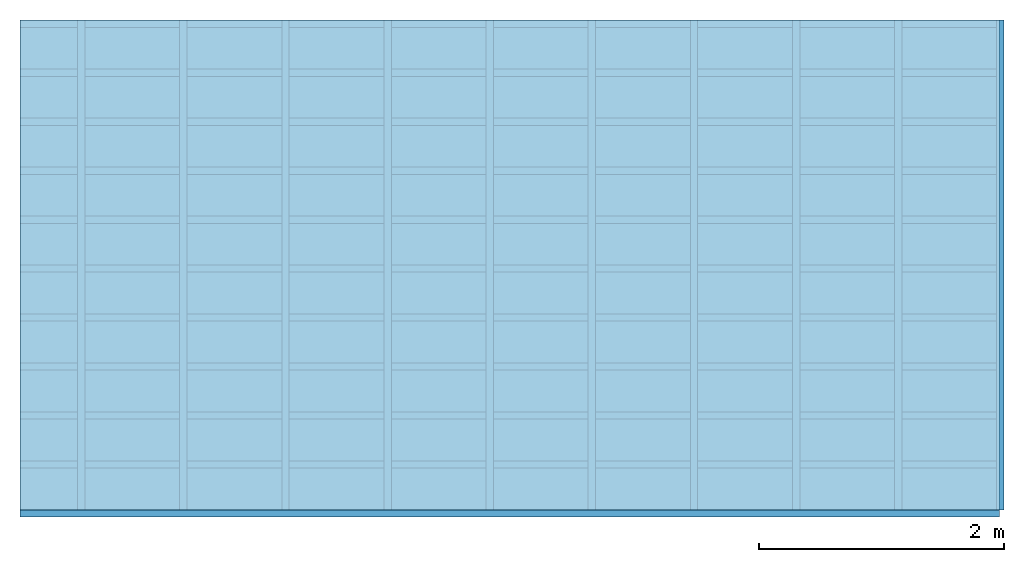
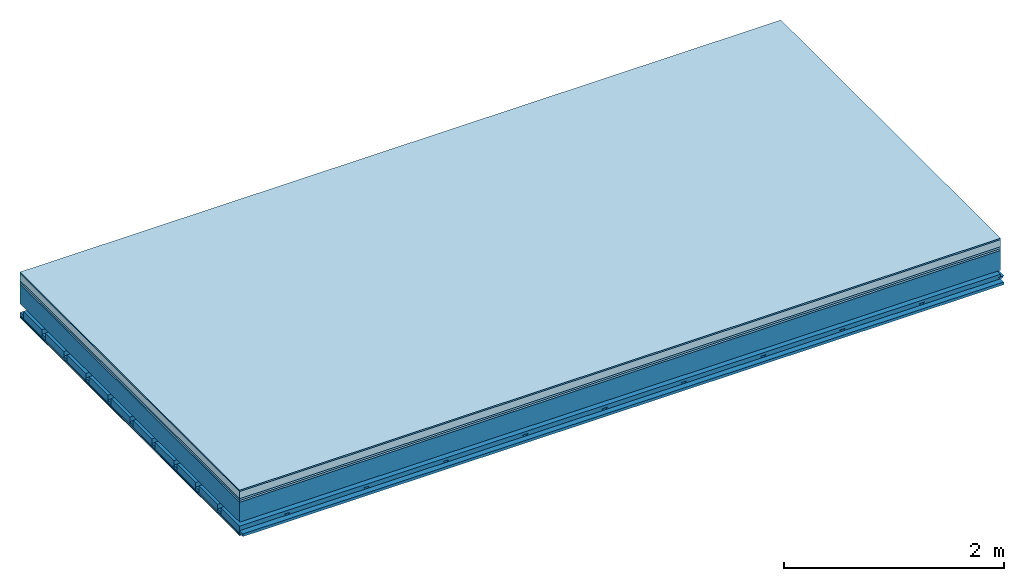
# One storey: 7 plates, 4 members, 1 element without a shape of its own.
"""IFC4 building model written with IfcOpenShell, lengths in metres."""

import ifcopenshell
import ifcopenshell.guid

model = None  # the IFC model being written
_history = None  # IfcOwnerHistory: only IFC2X3 demands one
_inside = {}  # id of a spatial element -> (the spatial element, [elements in it])
_under = {}  # id of a project, library or spatial element -> (it, [spatial elements below it])
_declared = {}  # id of a project -> (the project, [libraries it declares])
_typed = {}  # id of a type object -> (the type object, [elements of that type])
_made_of = {}  # id of a material, layer set ... -> (it, [elements and type objects made of it])


def new_model(schema):
    """Start an empty IFC model of exactly this schema.

    Asked for "IFC4X3", IfcOpenShell would pick the latest addendum, in which some entities
    have other attributes; the version numbers below select the first issue.
    IFC2X3 requires an IfcOwnerHistory on every rooted entity: one is made here for all.
    """
    global model, _history
    if schema == "IFC4X3":
        model = ifcopenshell.file(schema_version=(4, 3, 0, 0))
    else:
        model = ifcopenshell.file(schema=schema)
    _inside.clear()
    _under.clear()
    _declared.clear()
    _typed.clear()
    _made_of.clear()
    _history = None
    if model.schema == "IFC2X3":
        org = make("IfcOrganization", Name="unknown")
        user = make(
            "IfcPersonAndOrganization",
            ThePerson=make("IfcPerson", FamilyName="unknown"),
            TheOrganization=org,
        )
        app = make(
            "IfcApplication",
            ApplicationDeveloper=org,
            Version="unknown",
            ApplicationFullName="unknown",
            ApplicationIdentifier="unknown",
        )
        _history = make(
            "IfcOwnerHistory",
            OwningUser=user,
            OwningApplication=app,
            ChangeAction="ADDED",
            CreationDate=0,
        )
    return model


def make(cls, **values):
    """One entity of the class cls with the attributes given. An attribute that is None is left unset."""
    return model.create_entity(
        cls, **{name: value for name, value in values.items() if value is not None}
    )


def rooted(cls, **values):
    """An entity with a GlobalId (a new one), such as an element, a storey or a relation."""
    return make(cls, GlobalId=ifcopenshell.guid.new(), OwnerHistory=_history, **values)


def si_unit(unit_type, name, prefix=None):
    """IfcSIUnit, for example si_unit("LENGTHUNIT", "METRE", prefix="MILLI")."""
    return make("IfcSIUnit", UnitType=unit_type, Prefix=prefix, Name=name)


def derived_unit(unit_type, elements):
    """IfcDerivedUnit: a product of units, each with its exponent."""
    return make(
        "IfcDerivedUnit",
        Elements=[
            make("IfcDerivedUnitElement", Unit=unit, Exponent=power)
            for unit, power in elements
        ],
        UnitType=unit_type,
    )


def assignment(units):
    """IfcUnitAssignment: the units of a project."""
    return None if units is None else make("IfcUnitAssignment", Units=units)


def point(xyz):
    """IfcCartesianPoint."""
    return None if xyz is None else make("IfcCartesianPoint", Coordinates=xyz)


def direction(xyz):
    """IfcDirection."""
    return None if xyz is None else make("IfcDirection", DirectionRatios=xyz)


def frame(location, z_axis=None, x_axis=None):
    """IfcAxis2Placement3D, a coordinate frame: its origin and axes. An axis left out is left unset."""
    return make(
        "IfcAxis2Placement3D",
        Location=point(location),
        Axis=direction(z_axis),
        RefDirection=direction(x_axis),
    )


def frame_2d(location, x_axis=None):
    """IfcAxis2Placement2D, a coordinate frame in the plane: its origin and x axis."""
    return make(
        "IfcAxis2Placement2D", Location=point(location), RefDirection=direction(x_axis)
    )


def origin():
    """The frame at (0, 0, 0) with its axes left unset."""
    return frame((0.0, 0.0, 0.0))


def origin_with_axes():
    """The frame at (0, 0, 0) with the z axis (0, 0, 1) and the x axis (1, 0, 0) written out."""
    return frame((0.0, 0.0, 0.0), z_axis=(0.0, 0.0, 1.0), x_axis=(1.0, 0.0, 0.0))


def place(relative_to, where):
    """IfcLocalPlacement: puts the frame where relative to a parent placement (None: the world)."""
    return make(
        "IfcLocalPlacement", PlacementRelTo=relative_to, RelativePlacement=where
    )


def context(
    kind, dimensions, precision=None, world=None, true_north=None, identifier=None
):
    """IfcGeometricRepresentationContext, for example the 3D "Model" context."""
    return make(
        "IfcGeometricRepresentationContext",
        ContextIdentifier=identifier,
        ContextType=kind,
        CoordinateSpaceDimension=dimensions,
        Precision=precision,
        WorldCoordinateSystem=world,
        TrueNorth=true_north,
    )


def project(units=None, contexts=None):
    """IfcProject with its units and contexts."""
    return rooted(
        "IfcProject",
        Name="project",
        RepresentationContexts=contexts,
        UnitsInContext=assignment(units),
    )


def spatial(cls, under=None, at=None, **own):
    """A site, building, storey or space (cls), placed at a placement, below another one or the project."""
    s = rooted(cls, ObjectPlacement=at, **own)
    if under is not None:
        _under.setdefault(under.id(), (under, []))[1].append(s)
    return s


def polyline(points):
    """IfcPolyline through the points."""
    return make("IfcPolyline", Points=[point(p) for p in points])


def profile(cls, at=None, kind="AREA", **sizes):
    """A parametric profile (cls). Its sizes go by their IFC names, for example OverallWidth=200.0."""
    return make(cls, ProfileType=kind, Position=at, **sizes)


def rectangle(**sizes):
    """IfcRectangleProfileDef."""
    return profile("IfcRectangleProfileDef", **sizes)


def outline(outer, holes=None, kind="AREA"):
    """IfcArbitraryClosedProfileDef: a profile drawn as a closed curve; with holes, ...WithVoids."""
    if holes is None:
        return make("IfcArbitraryClosedProfileDef", ProfileType=kind, OuterCurve=outer)
    return make(
        "IfcArbitraryProfileDefWithVoids",
        ProfileType=kind,
        OuterCurve=outer,
        InnerCurves=holes,
    )


def extrude(swept, where, along, depth):
    """IfcExtrudedAreaSolid: the profile swept, set in the frame where, extruded along a direction by depth."""
    return make(
        "IfcExtrudedAreaSolid",
        SweptArea=swept,
        Position=where,
        ExtrudedDirection=direction(along),
        Depth=depth,
    )


def shape(context_of_items, identifier, shape_type, items):
    """IfcShapeRepresentation: the items that make up one representation, for example the "Body"."""
    return make(
        "IfcShapeRepresentation",
        ContextOfItems=context_of_items,
        RepresentationIdentifier=identifier,
        RepresentationType=shape_type,
        Items=items,
    )


def material(Name=None, Category=None):
    """IfcMaterial."""
    return make("IfcMaterial", Name=Name, Category=Category)


def layer(
    of_material, thickness, ventilated=None, Name=None, Category=None, Priority=None
):
    """IfcMaterialLayer: one layer of a wall or slab, of a material (None: an air gap)."""
    return make(
        "IfcMaterialLayer",
        Material=of_material,
        LayerThickness=thickness,
        IsVentilated=ventilated,
        Name=Name,
        Category=Category,
        Priority=Priority,
    )


def layer_set(layers, Name=None):
    """IfcMaterialLayerSet."""
    return make("IfcMaterialLayerSet", MaterialLayers=layers, LayerSetName=Name)


def made_of(thing, what):
    """Note that an element or type object is made of a material, layer set ...; save() writes the relation."""
    if what is not None:
        _made_of.setdefault(what.id(), (what, []))[1].append(thing)
    return thing


def type_object(cls, material=None, **own):
    """A type object (cls), such as IfcWallType, which elements share."""
    return made_of(rooted(cls, **own), material)


def element(
    cls,
    number,
    at=None,
    inside=None,
    cuts=None,
    type_object=None,
    material=None,
    context=None,
    identifier="Body",
    shape_type=None,
    held_by="IfcProductDefinitionShape",
    body=None,
    shapes=None,
    **own,
):
    """One element of the class cls, such as IfcWall. Its Tag is "e" and its number.

    at: its placement. inside: the storey or other place that contains it. cuts: it is an
    opening in that element (IfcRelVoidsElement). A single representation is given by context,
    identifier, shape_type and body (its items); several are given by shapes. held_by: the class
    of the entity that holds the representations. save() writes the other relations.
    """
    e = rooted(cls, Tag="e%d" % number, ObjectPlacement=at, **own)
    if body is not None:
        shapes = [shape(context, identifier, shape_type, body)]
    if shapes is not None:
        e.Representation = make(held_by, Representations=shapes)
    if inside is not None:
        _inside.setdefault(inside.id(), (inside, []))[1].append(e)
    if cuts is not None:
        rooted(
            "IfcRelVoidsElement", RelatingBuildingElement=cuts, RelatedOpeningElement=e
        )
    if type_object is not None:
        _typed.setdefault(type_object.id(), (type_object, []))[1].append(e)
    return made_of(e, material)


def aggregate(whole, parts):
    """IfcRelAggregates: a whole, such as a stair, and the parts it consists of."""
    return rooted("IfcRelAggregates", RelatingObject=whole, RelatedObjects=parts)


def save(model, path):
    """Write the relations noted so far, then the file.

    IfcRelAggregates (storeys below a building ...), IfcRelContainedInSpatialStructure (elements
    in a storey), IfcRelDefinesByType, IfcRelAssociatesMaterial and IfcRelDeclares: one each for
    every whole, place, type object, material and project.
    """
    for whole, parts in _under.values():
        aggregate(whole, parts)
    for where, things in _inside.values():
        rooted(
            "IfcRelContainedInSpatialStructure",
            RelatedElements=things,
            RelatingStructure=where,
        )
    for kind, things in _typed.values():
        rooted("IfcRelDefinesByType", RelatedObjects=things, RelatingType=kind)
    for what, things in _made_of.values():
        rooted("IfcRelAssociatesMaterial", RelatedObjects=things, RelatingMaterial=what)
    for by, libraries in _declared.values():
        rooted("IfcRelDeclares", RelatingContext=by, RelatedDefinitions=libraries)
    model.write(path)


model = new_model("IFC4")

# Units and contexts
plan_context = context("Plan", 3, precision=1e-05, world=origin(), true_north=direction((0.0, 1.0)))
model_context = context("Model", 3, precision=1e-05, world=origin(), true_north=direction((0.0, 1.0)))
ifc_project = project(units=[si_unit("LENGTHUNIT", "METRE"), derived_unit("SOUNDPRESSUREUNIT", [(si_unit("PRESSUREUNIT", "PASCAL", prefix="MICRO"), 0)]), si_unit("ENERGYUNIT", "JOULE", prefix="MEGA"), si_unit("MASSUNIT", "GRAM", prefix="KILO"), derived_unit("THERMALTRANSMITTANCEUNIT", [(si_unit("POWERUNIT", "WATT"), 1), (si_unit("AREAUNIT", "SQUARE_METRE"), -1), (si_unit("THERMODYNAMICTEMPERATUREUNIT", "KELVIN"), -1)]), derived_unit("AREADENSITYUNIT", [(si_unit("MASSUNIT", "GRAM", prefix="KILO"), 1), (si_unit("AREAUNIT", "SQUARE_METRE"), -1)]), derived_unit("USERDEFINED", [(si_unit("ENERGYUNIT", "JOULE", prefix="MEGA"), 1), (si_unit("AREAUNIT", "SQUARE_METRE"), -1)])], contexts=[plan_context, model_context])

# Site, building, storey
site = spatial("IfcSite", under=ifc_project)
building_placement = place(None, origin())
building = spatial("IfcBuilding", under=site, at=building_placement)
storey_placement = place(building_placement, origin())
storey = spatial("IfcBuildingStorey", under=building, at=storey_placement)

# Slab, members, plates
ifc_material_1 = material(Category="11.013")
ifc_layer_1 = layer(ifc_material_1, 0.015, Name="Flooring")
ifc_material_2 = material(Name="Cement screed", Category="04.006")
ifc_layer_2 = layer(ifc_material_2, 0.08, Name="On-material")
ifc_material_3 = material(Name="Wood fiber generic product", Category="10.009")
ifc_layer_3 = layer(ifc_material_3, 0.02, Name="Impact sound insulation")
ifc_material_4 = material(Category="10.004")
ifc_layer_4 = layer(ifc_material_4, 0.02, Name="Additional insulation")
ifc_material_5 = material(Name="no composite action")
ifc_layer_5 = layer(ifc_material_5, 0.0, Name="Bond")
ifc_layer_6 = layer(None, 0.22, Name="Supporting structure")
ifc_layer_7 = layer(ifc_material_5, 0.0, Name="Bond")
ifc_layer_8 = layer(None, 0.095, Name="Coupling")
ifc_layer_9 = layer(None, 0.03, Name="Battens / profiles")
ifc_material_6 = material(Name="Plasterboard type A", Category="03.008")
ifc_layer_10 = layer(ifc_material_6, 0.0125, Name="Ceiling covering 1st layer")
ifc_layer_11 = layer(ifc_material_6, 0.0125, Name="Ceiling covering layer 2")
ifc_material_7 = material(Category="04.001")
ifc_layer_12 = layer(ifc_material_7, 0.003, Name="Surface / treatment")
ifc_layer_set = layer_set([ifc_layer_1, ifc_layer_2, ifc_layer_3, ifc_layer_4, ifc_layer_5, ifc_layer_6, ifc_layer_7, ifc_layer_8, ifc_layer_9, ifc_layer_10, ifc_layer_11, ifc_layer_12])
slab_type = type_object("IfcSlabType", Name="A2155", PredefinedType="NOTDEFINED", material=ifc_layer_set)
slab_placement = place(None, frame((0.0, 0.0, 0.0), z_axis=(0.0, 0.0, -1.0), x_axis=(1.0, 0.0, 0.0)))
slab = element("IfcSlab", 1, at=slab_placement, inside=storey, type_object=slab_type, material=ifc_layer_set, Name="Slab #1")
ifc_material_8 = material(Name="Solid timber panel")
member_1_placement = place(slab_placement, origin())
member_1 = element("IfcMember", 2, at=member_1_placement, material=ifc_material_8, Name="Supporting structure", context=plan_context, shape_type="SweptSolid", body=[
    extrude(rectangle(XDim=1.0, YDim=0.22, at=frame_2d((0.5, 0.11), x_axis=(1.0, 0.0))), frame((0.0, 4.0, 0.135), z_axis=(0.0, -1.0, 0.0), x_axis=(1.0, 0.0, 0.0)), (0.0, 0.0, 1.0), 4.0),
    extrude(rectangle(XDim=1.0, YDim=0.22, at=frame_2d((0.5, 0.11), x_axis=(1.0, 0.0))), frame((1.0, 4.0, 0.135), z_axis=(0.0, -1.0, 0.0), x_axis=(1.0, 0.0, 0.0)), (0.0, 0.0, 1.0), 4.0),
    extrude(rectangle(XDim=1.0, YDim=0.22, at=frame_2d((0.5, 0.11), x_axis=(1.0, 0.0))), frame((2.0, 4.0, 0.135), z_axis=(0.0, -1.0, 0.0), x_axis=(1.0, 0.0, 0.0)), (0.0, 0.0, 1.0), 4.0),
    extrude(rectangle(XDim=1.0, YDim=0.22, at=frame_2d((0.5, 0.11), x_axis=(1.0, 0.0))), frame((3.0, 4.0, 0.135), z_axis=(0.0, -1.0, 0.0), x_axis=(1.0, 0.0, 0.0)), (0.0, 0.0, 1.0), 4.0),
    extrude(rectangle(XDim=1.0, YDim=0.22, at=frame_2d((0.5, 0.11), x_axis=(1.0, 0.0))), frame((4.0, 4.0, 0.135), z_axis=(0.0, -1.0, 0.0), x_axis=(1.0, 0.0, 0.0)), (0.0, 0.0, 1.0), 4.0),
    extrude(rectangle(XDim=1.0, YDim=0.22, at=frame_2d((0.5, 0.11), x_axis=(1.0, 0.0))), frame((5.0, 4.0, 0.135), z_axis=(0.0, -1.0, 0.0), x_axis=(1.0, 0.0, 0.0)), (0.0, 0.0, 1.0), 4.0),
    extrude(rectangle(XDim=1.0, YDim=0.22, at=frame_2d((0.5, 0.11), x_axis=(1.0, 0.0))), frame((6.0, 4.0, 0.135), z_axis=(0.0, -1.0, 0.0), x_axis=(1.0, 0.0, 0.0)), (0.0, 0.0, 1.0), 4.0),
    extrude(rectangle(XDim=1.0, YDim=0.22, at=frame_2d((0.5, 0.11), x_axis=(1.0, 0.0))), frame((7.0, 4.0, 0.135), z_axis=(0.0, -1.0, 0.0), x_axis=(1.0, 0.0, 0.0)), (0.0, 0.0, 1.0), 4.0),
])
ifc_material_9 = material()
member_2_placement = place(slab_placement, origin())
member_2 = element("IfcMember", 3, at=member_2_placement, material=ifc_material_9, Name="Coupling", context=plan_context, shape_type="SweptSolid", body=[
    extrude(outline(polyline([(0.0, 0.0), (0.06, 0.0), (0.04, 0.02), (0.02, 0.02), (0.0, 0.0)])), frame((0.47, 4.0, 0.43), z_axis=(0.0, -1.0, 0.0), x_axis=(1.0, 0.0, 0.0)), (0.0, 0.0, 1.0), 4.0),
    extrude(outline(polyline([(0.0, 0.0), (0.06, 0.0), (0.04, 0.02), (0.02, 0.02), (0.0, 0.0)])), frame((1.304, 4.0, 0.43), z_axis=(0.0, -1.0, 0.0), x_axis=(1.0, 0.0, 0.0)), (0.0, 0.0, 1.0), 4.0),
    extrude(outline(polyline([(0.0, 0.0), (0.06, 0.0), (0.04, 0.02), (0.02, 0.02), (0.0, 0.0)])), frame((2.138, 4.0, 0.43), z_axis=(0.0, -1.0, 0.0), x_axis=(1.0, 0.0, 0.0)), (0.0, 0.0, 1.0), 4.0),
    extrude(outline(polyline([(0.0, 0.0), (0.06, 0.0), (0.04, 0.02), (0.02, 0.02), (0.0, 0.0)])), frame((2.972, 4.0, 0.43), z_axis=(0.0, -1.0, 0.0), x_axis=(1.0, 0.0, 0.0)), (0.0, 0.0, 1.0), 4.0),
    extrude(outline(polyline([(0.0, 0.0), (0.06, 0.0), (0.04, 0.02), (0.02, 0.02), (0.0, 0.0)])), frame((3.806, 4.0, 0.43), z_axis=(0.0, -1.0, 0.0), x_axis=(1.0, 0.0, 0.0)), (0.0, 0.0, 1.0), 4.0),
    extrude(outline(polyline([(0.0, 0.0), (0.06, 0.0), (0.04, 0.02), (0.02, 0.02), (0.0, 0.0)])), frame((4.64, 4.0, 0.43), z_axis=(0.0, -1.0, 0.0), x_axis=(1.0, 0.0, 0.0)), (0.0, 0.0, 1.0), 4.0),
    extrude(outline(polyline([(0.0, 0.0), (0.06, 0.0), (0.04, 0.02), (0.02, 0.02), (0.0, 0.0)])), frame((5.474, 4.0, 0.43), z_axis=(0.0, -1.0, 0.0), x_axis=(1.0, 0.0, 0.0)), (0.0, 0.0, 1.0), 4.0),
    extrude(outline(polyline([(0.0, 0.0), (0.06, 0.0), (0.04, 0.02), (0.02, 0.02), (0.0, 0.0)])), frame((6.308, 4.0, 0.43), z_axis=(0.0, -1.0, 0.0), x_axis=(1.0, 0.0, 0.0)), (0.0, 0.0, 1.0), 4.0),
    extrude(outline(polyline([(0.0, 0.0), (0.06, 0.0), (0.04, 0.02), (0.02, 0.02), (0.0, 0.0)])), frame((7.142, 4.0, 0.43), z_axis=(0.0, -1.0, 0.0), x_axis=(1.0, 0.0, 0.0)), (0.0, 0.0, 1.0), 4.0),
    extrude(outline(polyline([(0.0, 0.0), (0.06, 0.0), (0.04, 0.02), (0.02, 0.02), (0.0, 0.0)])), frame((7.976, 4.0, 0.43), z_axis=(0.0, -1.0, 0.0), x_axis=(1.0, 0.0, 0.0)), (0.0, 0.0, 1.0), 4.0),
])
member_3_placement = place(slab_placement, origin())
member_3 = element("IfcMember", 4, at=member_3_placement, material=ifc_material_9, Name="Battens / profiles", context=plan_context, shape_type="SweptSolid", body=[
    extrude(rectangle(XDim=0.06, YDim=0.03, at=frame_2d((0.03, 0.015), x_axis=(1.0, 0.0))), frame((0.0, 0.0, 0.45), z_axis=(1.0, 0.0, 0.0), x_axis=(0.0, 1.0, 0.0)), (0.0, 0.0, 1.0), 8.0),
    extrude(rectangle(XDim=0.06, YDim=0.03, at=frame_2d((0.03, 0.015), x_axis=(1.0, 0.0))), frame((0.0, 0.4, 0.45), z_axis=(1.0, 0.0, 0.0), x_axis=(0.0, 1.0, 0.0)), (0.0, 0.0, 1.0), 8.0),
    extrude(rectangle(XDim=0.06, YDim=0.03, at=frame_2d((0.03, 0.015), x_axis=(1.0, 0.0))), frame((0.0, 0.8, 0.45), z_axis=(1.0, 0.0, 0.0), x_axis=(0.0, 1.0, 0.0)), (0.0, 0.0, 1.0), 8.0),
    extrude(rectangle(XDim=0.06, YDim=0.03, at=frame_2d((0.03, 0.015), x_axis=(1.0, 0.0))), frame((0.0, 1.2, 0.45), z_axis=(1.0, 0.0, 0.0), x_axis=(0.0, 1.0, 0.0)), (0.0, 0.0, 1.0), 8.0),
    extrude(rectangle(XDim=0.06, YDim=0.03, at=frame_2d((0.03, 0.015), x_axis=(1.0, 0.0))), frame((0.0, 1.6, 0.45), z_axis=(1.0, 0.0, 0.0), x_axis=(0.0, 1.0, 0.0)), (0.0, 0.0, 1.0), 8.0),
    extrude(rectangle(XDim=0.06, YDim=0.03, at=frame_2d((0.03, 0.015), x_axis=(1.0, 0.0))), frame((0.0, 2.0, 0.45), z_axis=(1.0, 0.0, 0.0), x_axis=(0.0, 1.0, 0.0)), (0.0, 0.0, 1.0), 8.0),
    extrude(rectangle(XDim=0.06, YDim=0.03, at=frame_2d((0.03, 0.015), x_axis=(1.0, 0.0))), frame((0.0, 2.4, 0.45), z_axis=(1.0, 0.0, 0.0), x_axis=(0.0, 1.0, 0.0)), (0.0, 0.0, 1.0), 8.0),
    extrude(rectangle(XDim=0.06, YDim=0.03, at=frame_2d((0.03, 0.015), x_axis=(1.0, 0.0))), frame((0.0, 2.8, 0.45), z_axis=(1.0, 0.0, 0.0), x_axis=(0.0, 1.0, 0.0)), (0.0, 0.0, 1.0), 8.0),
    extrude(rectangle(XDim=0.06, YDim=0.03, at=frame_2d((0.03, 0.015), x_axis=(1.0, 0.0))), frame((0.0, 3.2, 0.45), z_axis=(1.0, 0.0, 0.0), x_axis=(0.0, 1.0, 0.0)), (0.0, 0.0, 1.0), 8.0),
    extrude(rectangle(XDim=0.06, YDim=0.03, at=frame_2d((0.03, 0.015), x_axis=(1.0, 0.0))), frame((0.0, 3.6, 0.45), z_axis=(1.0, 0.0, 0.0), x_axis=(0.0, 1.0, 0.0)), (0.0, 0.0, 1.0), 8.0),
    extrude(rectangle(XDim=0.06, YDim=0.03, at=frame_2d((0.03, 0.015), x_axis=(1.0, 0.0))), frame((0.0, 4.0, 0.45), z_axis=(1.0, 0.0, 0.0), x_axis=(0.0, 1.0, 0.0)), (0.0, 0.0, 1.0), 8.0),
])
ifc_material_10 = material()
member_4_placement = place(slab_placement, origin())
member_4 = element("IfcMember", 5, at=member_4_placement, material=ifc_material_10, Name="Cavity", context=plan_context, shape_type="SweptSolid", body=[
    extrude(rectangle(XDim=0.34, YDim=0.08, at=frame_2d((0.17, 0.04), x_axis=(1.0, 0.0))), frame((0.0, 0.06, 0.4), z_axis=(1.0, 0.0, 0.0), x_axis=(0.0, 1.0, 0.0)), (0.0, 0.0, 1.0), 8.0),
    extrude(rectangle(XDim=0.34, YDim=0.08, at=frame_2d((0.17, 0.04), x_axis=(1.0, 0.0))), frame((0.0, 0.46, 0.4), z_axis=(1.0, 0.0, 0.0), x_axis=(0.0, 1.0, 0.0)), (0.0, 0.0, 1.0), 8.0),
    extrude(rectangle(XDim=0.34, YDim=0.08, at=frame_2d((0.17, 0.04), x_axis=(1.0, 0.0))), frame((0.0, 0.86, 0.4), z_axis=(1.0, 0.0, 0.0), x_axis=(0.0, 1.0, 0.0)), (0.0, 0.0, 1.0), 8.0),
    extrude(rectangle(XDim=0.34, YDim=0.08, at=frame_2d((0.17, 0.04), x_axis=(1.0, 0.0))), frame((0.0, 1.26, 0.4), z_axis=(1.0, 0.0, 0.0), x_axis=(0.0, 1.0, 0.0)), (0.0, 0.0, 1.0), 8.0),
    extrude(rectangle(XDim=0.34, YDim=0.08, at=frame_2d((0.17, 0.04), x_axis=(1.0, 0.0))), frame((0.0, 1.66, 0.4), z_axis=(1.0, 0.0, 0.0), x_axis=(0.0, 1.0, 0.0)), (0.0, 0.0, 1.0), 8.0),
    extrude(rectangle(XDim=0.34, YDim=0.08, at=frame_2d((0.17, 0.04), x_axis=(1.0, 0.0))), frame((0.0, 2.06, 0.4), z_axis=(1.0, 0.0, 0.0), x_axis=(0.0, 1.0, 0.0)), (0.0, 0.0, 1.0), 8.0),
    extrude(rectangle(XDim=0.34, YDim=0.08, at=frame_2d((0.17, 0.04), x_axis=(1.0, 0.0))), frame((0.0, 2.46, 0.4), z_axis=(1.0, 0.0, 0.0), x_axis=(0.0, 1.0, 0.0)), (0.0, 0.0, 1.0), 8.0),
    extrude(rectangle(XDim=0.34, YDim=0.08, at=frame_2d((0.17, 0.04), x_axis=(1.0, 0.0))), frame((0.0, 2.86, 0.4), z_axis=(1.0, 0.0, 0.0), x_axis=(0.0, 1.0, 0.0)), (0.0, 0.0, 1.0), 8.0),
    extrude(rectangle(XDim=0.34, YDim=0.08, at=frame_2d((0.17, 0.04), x_axis=(1.0, 0.0))), frame((0.0, 3.26, 0.4), z_axis=(1.0, 0.0, 0.0), x_axis=(0.0, 1.0, 0.0)), (0.0, 0.0, 1.0), 8.0),
    extrude(rectangle(XDim=0.34, YDim=0.08, at=frame_2d((0.17, 0.04), x_axis=(1.0, 0.0))), frame((0.0, 3.66, 0.4), z_axis=(1.0, 0.0, 0.0), x_axis=(0.0, 1.0, 0.0)), (0.0, 0.0, 1.0), 8.0),
])
plate_1_placement = place(slab_placement, origin())
plate_1 = element("IfcPlate", 6, at=plate_1_placement, material=ifc_material_1, Name="Flooring", context=plan_context, shape_type="SweptSolid", body=[
    extrude(rectangle(XDim=8.0, YDim=4.0, at=frame_2d((4.0, 2.0), x_axis=(1.0, 0.0))), origin_with_axes(), (0.0, 0.0, 1.0), 0.015),
])
plate_2_placement = place(slab_placement, origin())
plate_2 = element("IfcPlate", 7, at=plate_2_placement, material=ifc_material_2, Name="On-material", context=plan_context, shape_type="SweptSolid", body=[
    extrude(rectangle(XDim=8.0, YDim=4.0, at=frame_2d((4.0, 2.0), x_axis=(1.0, 0.0))), frame((0.0, 0.0, 0.015), z_axis=(0.0, 0.0, 1.0), x_axis=(1.0, 0.0, 0.0)), (0.0, 0.0, 1.0), 0.08),
])
plate_3_placement = place(slab_placement, origin())
plate_3 = element("IfcPlate", 8, at=plate_3_placement, material=ifc_material_3, Name="Impact sound insulation", context=plan_context, shape_type="SweptSolid", body=[
    extrude(rectangle(XDim=8.0, YDim=4.0, at=frame_2d((4.0, 2.0), x_axis=(1.0, 0.0))), frame((0.0, 0.0, 0.095), z_axis=(0.0, 0.0, 1.0), x_axis=(1.0, 0.0, 0.0)), (0.0, 0.0, 1.0), 0.02),
])
plate_4_placement = place(slab_placement, origin())
plate_4 = element("IfcPlate", 9, at=plate_4_placement, material=ifc_material_4, Name="Additional insulation", context=plan_context, shape_type="SweptSolid", body=[
    extrude(rectangle(XDim=8.0, YDim=4.0, at=frame_2d((4.0, 2.0), x_axis=(1.0, 0.0))), frame((0.0, 0.0, 0.115), z_axis=(0.0, 0.0, 1.0), x_axis=(1.0, 0.0, 0.0)), (0.0, 0.0, 1.0), 0.02),
])
plate_5_placement = place(slab_placement, origin())
plate_5 = element("IfcPlate", 10, at=plate_5_placement, material=ifc_material_6, Name="Ceiling covering 1st layer", context=plan_context, shape_type="SweptSolid", body=[
    extrude(rectangle(XDim=8.0, YDim=4.0, at=frame_2d((4.0, 2.0), x_axis=(1.0, 0.0))), frame((0.0, 0.0, 0.48), z_axis=(0.0, 0.0, 1.0), x_axis=(1.0, 0.0, 0.0)), (0.0, 0.0, 1.0), 0.0125),
])
plate_6_placement = place(slab_placement, origin())
plate_6 = element("IfcPlate", 11, at=plate_6_placement, material=ifc_material_6, Name="Ceiling covering layer 2", context=plan_context, shape_type="SweptSolid", body=[
    extrude(rectangle(XDim=8.0, YDim=4.0, at=frame_2d((4.0, 2.0), x_axis=(1.0, 0.0))), frame((0.0, 0.0, 0.4925), z_axis=(0.0, 0.0, 1.0), x_axis=(1.0, 0.0, 0.0)), (0.0, 0.0, 1.0), 0.0125),
])
plate_7_placement = place(slab_placement, origin())
plate_7 = element("IfcPlate", 12, at=plate_7_placement, material=ifc_material_7, Name="Surface / treatment", context=plan_context, shape_type="SweptSolid", body=[
    extrude(rectangle(XDim=8.0, YDim=4.0, at=frame_2d((4.0, 2.0), x_axis=(1.0, 0.0))), frame((0.0, 0.0, 0.505), z_axis=(0.0, 0.0, 1.0), x_axis=(1.0, 0.0, 0.0)), (0.0, 0.0, 1.0), 0.003),
])
aggregate(slab, [plate_1, plate_2, plate_3, plate_4, member_1, member_2, member_3, member_4, plate_5, plate_6, plate_7])

save(model, "model.ifc")
